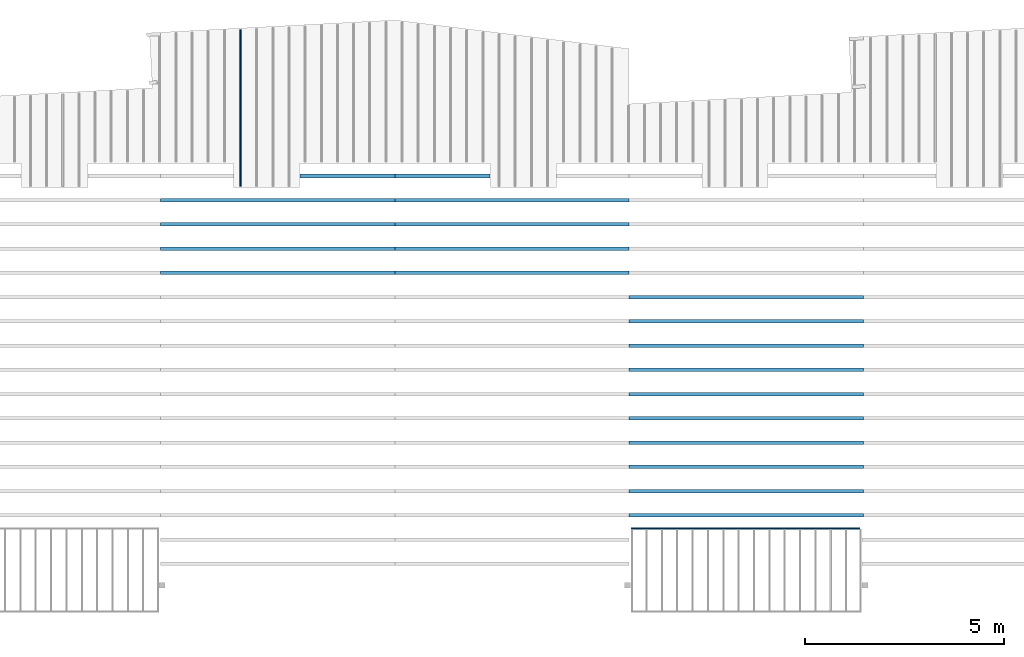
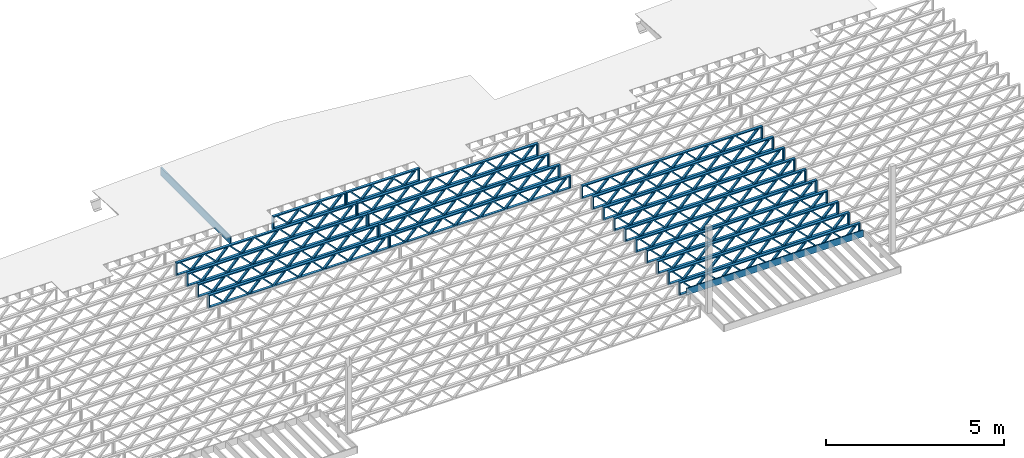
# One storey, part 7 of 12: 22 beams, 4 elements without a shape of their own.
"""IFC4 building model written with IfcOpenShell, lengths in feet."""

from ifc_helpers import new_model, entity, si_unit, converted_unit, derived_unit, direction, frame, frame_2d, origin, origin_2d_with_axis, place, context, subcontext, project, spatial, rectangle, extrude, source, transform, mapped, material, material_profile, profile_set, profile_usage, type_object, type_shapes, element, aggregate, save


model = new_model("IFC4")

# Units and contexts
model_context = context("Model", 3, precision=0.0001, world=origin(), true_north=direction((6.12303176911189e-17, 1.0)))
body_context = subcontext(model_context, "Body", "Model", "MODEL_VIEW")
ifc_project = project(units=[converted_unit("LENGTHUNIT", "FOOT", entity("IfcRatioMeasure", 0.3048), si_unit("LENGTHUNIT", "METRE"), dimensions=[1, 0, 0, 0, 0, 0, 0]), converted_unit("AREAUNIT", "SQUARE FOOT", entity("IfcRatioMeasure", 0.09290304), si_unit("AREAUNIT", "SQUARE_METRE"), dimensions=[2, 0, 0, 0, 0, 0, 0]), converted_unit("VOLUMEUNIT", "CUBIC FOOT", entity("IfcRatioMeasure", 0.028316846592), si_unit("VOLUMEUNIT", "CUBIC_METRE"), dimensions=[3, 0, 0, 0, 0, 0, 0]), converted_unit("PLANEANGLEUNIT", "DEGREE", entity("IfcRatioMeasure", 0.0174532925199433), si_unit("PLANEANGLEUNIT", "RADIAN"), dimensions=[0, 0, 0, 0, 0, 0, 0]), si_unit("MASSUNIT", "GRAM", prefix="KILO"), derived_unit("MASSDENSITYUNIT", [(si_unit("MASSUNIT", "GRAM", prefix="KILO"), 1), (si_unit("LENGTHUNIT", "METRE"), -3)]), derived_unit("MOMENTOFINERTIAUNIT", [(si_unit("LENGTHUNIT", "METRE"), 4)]), si_unit("TIMEUNIT", "SECOND"), si_unit("FREQUENCYUNIT", "HERTZ"), si_unit("THERMODYNAMICTEMPERATUREUNIT", "DEGREE_CELSIUS"), derived_unit("THERMALTRANSMITTANCEUNIT", [(si_unit("MASSUNIT", "GRAM", prefix="KILO"), 1), (si_unit("THERMODYNAMICTEMPERATUREUNIT", "KELVIN"), -1), (si_unit("TIMEUNIT", "SECOND"), -3)]), derived_unit("VOLUMETRICFLOWRATEUNIT", [(si_unit("LENGTHUNIT", "METRE"), 3), (si_unit("TIMEUNIT", "SECOND"), -1)]), si_unit("ELECTRICCURRENTUNIT", "AMPERE"), si_unit("ELECTRICVOLTAGEUNIT", "VOLT"), si_unit("POWERUNIT", "WATT"), si_unit("FORCEUNIT", "NEWTON"), si_unit("ILLUMINANCEUNIT", "LUX"), si_unit("LUMINOUSFLUXUNIT", "LUMEN"), si_unit("LUMINOUSINTENSITYUNIT", "CANDELA"), derived_unit("USERDEFINED", [(si_unit("MASSUNIT", "GRAM", prefix="KILO"), -1), (si_unit("LENGTHUNIT", "METRE"), -2), (si_unit("TIMEUNIT", "SECOND"), 3), (si_unit("LUMINOUSFLUXUNIT", "LUMEN"), 1)]), derived_unit("LINEARVELOCITYUNIT", [(si_unit("LENGTHUNIT", "METRE"), 1), (si_unit("TIMEUNIT", "SECOND"), -1)]), si_unit("PRESSUREUNIT", "PASCAL"), derived_unit("USERDEFINED", [(si_unit("LENGTHUNIT", "METRE"), -2), (si_unit("MASSUNIT", "GRAM", prefix="KILO"), 1), (si_unit("TIMEUNIT", "SECOND"), -2)]), derived_unit("LINEARFORCEUNIT", [(si_unit("MASSUNIT", "GRAM", prefix="KILO"), 1), (si_unit("LENGTHUNIT", "METRE"), 1), (si_unit("TIMEUNIT", "SECOND"), -2), (si_unit("LENGTHUNIT", "METRE"), -1)]), derived_unit("PLANARFORCEUNIT", [(si_unit("MASSUNIT", "GRAM", prefix="KILO"), 1), (si_unit("LENGTHUNIT", "METRE"), 1), (si_unit("TIMEUNIT", "SECOND"), -2), (si_unit("LENGTHUNIT", "METRE"), -2)])], contexts=[model_context])

# Site, building, storey
site_placement = place(None, origin())
site = spatial("IfcSite", under=ifc_project, at=site_placement, CompositionType="ELEMENT")
building_placement = place(site_placement, origin())
building = spatial("IfcBuilding", under=site, at=building_placement, CompositionType="ELEMENT")
storey_placement = place(building_placement, frame((0.0, 0.0, 21.46875)))
storey = spatial("IfcBuildingStorey", under=building, at=storey_placement, Name="3RD FLOOR", CompositionType="ELEMENT", Elevation=21.46875)

# Assembly, beams
assembly_1_placement = place(storey_placement, origin())
assembly_1 = element("IfcElementAssembly", 1, at=assembly_1_placement, inside=storey, Name="Structural Beam System:Structural Framing System", ObjectType="Structural Beam System:Structural Framing System", AssemblyPlace="NOTDEFINED", PredefinedType="BEAM_GRID")
ifc_material_1 = material(Name="WOOD TRUSS", Category="Materials")
ifc_material_profile_1 = material_profile(ifc_material_1, rectangle(XDim=1.73473973950632, YDim=0.125, at=frame_2d((-1.11022302462516e-16, 8.32667268468867e-17), x_axis=(1.0, 0.0))))
ifc_material_profile_2 = material_profile(ifc_material_1, rectangle(XDim=1.73473973950633, YDim=0.125, at=frame_2d((-1.11022302462516e-16, 8.32667268468867e-17), x_axis=(1.0, 0.0))))
ifc_material_profile_3 = material_profile(ifc_material_1, rectangle(XDim=1.73473973950632, YDim=0.125, at=frame_2d((-5.55111512312578e-17, 1.38777878078145e-16), x_axis=(1.0, 0.0))))
ifc_material_profile_4 = material_profile(ifc_material_1, rectangle(XDim=1.73473973950633, YDim=0.125, at=frame_2d((-1.11022302462516e-16, 8.32667268468867e-17), x_axis=(1.0, 0.0))))
ifc_material_profile_5 = material_profile(ifc_material_1, rectangle(XDim=1.73473973950632, YDim=0.125, at=frame_2d((-1.11022302462516e-16, 8.32667268468867e-17), x_axis=(1.0, 0.0))))
ifc_material_profile_6 = material_profile(ifc_material_1, rectangle(XDim=1.73473973950633, YDim=0.125, at=frame_2d((-2.77555756156289e-16, 3.05311331771918e-16), x_axis=(1.0, 0.0))))
ifc_material_profile_7 = material_profile(ifc_material_1, rectangle(XDim=1.73473973950632, YDim=0.124999999999999, at=frame_2d((-3.88578058618805e-16, -2.4980018054066e-16), x_axis=(1.0, 0.0))))
ifc_material_profile_8 = material_profile(ifc_material_1, rectangle(XDim=1.73473973950633, YDim=0.125, at=frame_2d((2.77555756156289e-16, -3.05311331771918e-16), x_axis=(1.0, 0.0))))
ifc_material_profile_9 = material_profile(ifc_material_1, rectangle(XDim=1.73473973950632, YDim=0.124999999999999, at=frame_2d((-1.11022302462516e-16, 8.32667268468867e-17), x_axis=(1.0, 0.0))))
ifc_material_profile_10 = material_profile(ifc_material_1, rectangle(XDim=1.73473973950633, YDim=0.125, at=origin_2d_with_axis()))
ifc_material_profile_11 = material_profile(ifc_material_1, rectangle(XDim=0.124999999999982, YDim=0.291666666666668, at=origin_2d_with_axis()))
ifc_material_profile_12 = material_profile(ifc_material_1, rectangle(XDim=0.124999999999932, YDim=0.291666666666664, at=origin_2d_with_axis()))
ifc_material_profile_13 = material_profile(ifc_material_1, rectangle(XDim=1.25000000000002, YDim=0.29166666666667, at=origin_2d_with_axis()))
ifc_material_profile_14 = material_profile(ifc_material_1, rectangle(XDim=1.25000000000004, YDim=0.291666666666667, at=origin_2d_with_axis()))
ifc_profile_set_1 = profile_set([ifc_material_profile_1, ifc_material_profile_2, ifc_material_profile_3, ifc_material_profile_4, ifc_material_profile_5, ifc_material_profile_6, ifc_material_profile_7, ifc_material_profile_8, ifc_material_profile_9, ifc_material_profile_10, ifc_material_profile_11, ifc_material_profile_12, ifc_material_profile_13, ifc_material_profile_14])
ifc_profile_usage_1 = profile_usage(ifc_profile_set_1, cardinal=8)
beam_type_1 = type_object("IfcBeamType", PredefinedType="BEAM", material=ifc_profile_set_1)
shared_shape_1 = source(origin(), body_context, "Body", "SweptSolid", [
    extrude(rectangle(XDim=1.73473973950632, YDim=0.124999999999999, at=frame_2d((5.55111512312578e-16, 7.21644966006352e-16), x_axis=(1.0, 0.0))), frame((5.95847627016997, -0.145833333333334, 0.0), z_axis=(0.0, 1.0, 0.0), x_axis=(0.693383046997606, 0.0, 0.720569184836762)), (0.0, 0.0, 1.0), 0.291666666666667),
    extrude(rectangle(XDim=1.73473973950633, YDim=0.125, at=origin_2d_with_axis()), frame((4.7081903964967, -0.145833333333334, 0.0), z_axis=(0.0, 1.0, 0.0), x_axis=(0.69338304699761, 0.0, -0.720569184836758)), (0.0, 0.0, 1.0), 0.291666666666666),
    extrude(rectangle(XDim=1.73473973950632, YDim=0.125, at=frame_2d((2.22044604925031e-16, 3.88578058618805e-16), x_axis=(1.0, 0.0))), frame((3.29180960350347, -0.145833333333334, 0.0), z_axis=(0.0, 1.0, 0.0), x_axis=(0.693383046997606, 0.0, 0.720569184836762)), (0.0, 0.0, 1.0), 0.291666666666667),
    extrude(rectangle(XDim=1.73473973950633, YDim=0.125, at=frame_2d((1.11022302462516e-16, -8.32667268468867e-17), x_axis=(1.0, 0.0))), frame((2.0415237298302, -0.145833333333334, 0.0), z_axis=(0.0, 1.0, 0.0), x_axis=(0.69338304699761, 0.0, -0.720569184836758)), (0.0, 0.0, 1.0), 0.291666666666667),
    extrude(rectangle(XDim=1.73473973950632, YDim=0.125, at=frame_2d((-5.55111512312578e-17, 1.38777878078145e-16), x_axis=(1.0, 0.0))), frame((0.625142936836964, -0.145833333333334, 0.0), z_axis=(0.0, 1.0, 0.0), x_axis=(0.693383046997606, 0.0, 0.720569184836762)), (0.0, 0.0, 1.0), 0.291666666666667),
    extrude(rectangle(XDim=1.73473973950633, YDim=0.125, at=frame_2d((-1.11022302462516e-16, 8.32667268468867e-17), x_axis=(1.0, 0.0))), frame((-0.625142936836306, -0.145833333333334, 0.0), z_axis=(0.0, 1.0, 0.0), x_axis=(0.69338304699761, 0.0, -0.720569184836758)), (0.0, 0.0, 1.0), 0.291666666666667),
    extrude(rectangle(XDim=1.73473973950632, YDim=0.125, at=frame_2d((-1.11022302462516e-16, 8.32667268468867e-17), x_axis=(1.0, 0.0))), frame((-2.04152372982954, -0.145833333333334, 0.0), z_axis=(0.0, 1.0, 0.0), x_axis=(0.693383046997606, 0.0, 0.720569184836762)), (0.0, 0.0, 1.0), 0.291666666666667),
    extrude(rectangle(XDim=1.73473973950633, YDim=0.125, at=origin_2d_with_axis()), frame((-3.29180960350281, -0.145833333333334, 0.0), z_axis=(0.0, 1.0, 0.0), x_axis=(0.69338304699761, 0.0, -0.720569184836758)), (0.0, 0.0, 1.0), 0.291666666666667),
    extrude(rectangle(XDim=1.73473973950632, YDim=0.124999999999999, at=frame_2d((-1.11022302462516e-16, 8.32667268468867e-17), x_axis=(1.0, 0.0))), frame((-4.70819039649604, -0.145833333333334, 0.0), z_axis=(0.0, 1.0, 0.0), x_axis=(0.693383046997606, 0.0, 0.720569184836762)), (0.0, 0.0, 1.0), 0.291666666666667),
    extrude(rectangle(XDim=1.73473973950633, YDim=0.125, at=frame_2d((-5.55111512312578e-16, 6.38378239159465e-16), x_axis=(1.0, 0.0))), frame((-5.95847627016931, -0.145833333333334, 0.0), z_axis=(0.0, 1.0, 0.0), x_axis=(0.69338304699761, 0.0, -0.720569184836758)), (0.0, 0.0, 1.0), 0.291666666666666),
    extrude(rectangle(XDim=1.73473973950632, YDim=0.125, at=frame_2d((-7.21644966006352e-16, -5.82867087928207e-16), x_axis=(1.0, 0.0))), frame((8.62514293683647, -0.145833333333334, 0.0), z_axis=(0.0, 1.0, 0.0), x_axis=(0.693383046997607, 0.0, 0.720569184836761)), (0.0, 0.0, 1.0), 0.291666666666667),
    extrude(rectangle(XDim=1.73473973950633, YDim=0.125, at=origin_2d_with_axis()), frame((7.3748570631632, -0.145833333333334, 0.0), z_axis=(0.0, 1.0, 0.0), x_axis=(0.69338304699761, 0.0, -0.720569184836758)), (0.0, 0.0, 1.0), 0.291666666666666),
    extrude(rectangle(XDim=1.73473973950632, YDim=0.124999999999999, at=frame_2d((-1.11022302462516e-16, 8.32667268468867e-17), x_axis=(1.0, 0.0))), frame((-7.37485706316255, -0.145833333333334, 0.0), z_axis=(0.0, 1.0, 0.0), x_axis=(0.693383046997606, 0.0, 0.720569184836762)), (0.0, 0.0, 1.0), 0.291666666666667),
    extrude(rectangle(XDim=1.73473973950633, YDim=0.125, at=origin_2d_with_axis()), frame((-8.62514293683582, -0.145833333333334, 0.0), z_axis=(0.0, 1.0, 0.0), x_axis=(0.69338304699761, 0.0, -0.720569184836758)), (0.0, 0.0, 1.0), 0.291666666666666),
    extrude(rectangle(XDim=0.124999999999982, YDim=0.291666666666668, at=origin_2d_with_axis()), frame((-9.66666666666609, 0.0, 0.687500000000054), z_axis=(1.0, 0.0, 0.0), x_axis=(0.0, 0.0, -1.0)), (0.0, 0.0, 1.0), 19.3333333333322),
    extrude(rectangle(XDim=0.124999999999932, YDim=0.291666666666664, at=origin_2d_with_axis()), frame((-9.66666666666588, 0.0, -0.687499999999984), z_axis=(1.0, 0.0, 0.0), x_axis=(0.0, 0.0, -1.0)), (0.0, 0.0, 1.0), 19.333333333332),
    extrude(rectangle(XDim=1.25000000000002, YDim=0.29166666666667, at=origin_2d_with_axis()), frame((9.54166666666607, 0.0, 0.0), z_axis=(1.0, 0.0, 0.0), x_axis=(0.0, 0.0, -1.0)), (0.0, 0.0, 1.0), 0.12500000000002),
    extrude(rectangle(XDim=1.25000000000004, YDim=0.291666666666667, at=origin_2d_with_axis()), frame((-9.66666666666609, 0.0, 0.0), z_axis=(1.0, 0.0, 0.0), x_axis=(0.0, 0.0, -1.0)), (0.0, 0.0, 1.0), 0.125000000000023),
])
type_shapes(beam_type_1, [shared_shape_1])
beam_1_placement = place(assembly_1_placement, frame((-174.071493818896, 947.861934882651, -0.947916666666661), z_axis=(0.0, 0.0, 1.0), x_axis=(-1.0, 0.0, 0.0)))
beam_1 = element("IfcBeam", 2, at=beam_1_placement, type_object=beam_type_1, material=ifc_profile_usage_1, PredefinedType="BEAM", context=body_context, shape_type="MappedRepresentation", body=[
    mapped(shared_shape_1, transform((0.0, 0.0, 0.0), scale=1.0)),
])
ifc_profile_usage_2 = profile_usage(ifc_profile_set_1, cardinal=8)
beam_2_placement = place(assembly_1_placement, frame((-174.071493818896, 945.861934882651, -0.947916666666661), z_axis=(0.0, 0.0, 1.0), x_axis=(-1.0, 0.0, 0.0)))
beam_2 = element("IfcBeam", 3, at=beam_2_placement, type_object=beam_type_1, material=ifc_profile_usage_2, PredefinedType="BEAM", context=body_context, shape_type="MappedRepresentation", body=[
    mapped(shared_shape_1, transform((0.0, 0.0, 0.0), scale=1.0)),
])
ifc_profile_usage_3 = profile_usage(ifc_profile_set_1, cardinal=8)
beam_3_placement = place(assembly_1_placement, frame((-174.071493818896, 943.861934882651, -0.947916666666661), z_axis=(0.0, 0.0, 1.0), x_axis=(-1.0, 0.0, 0.0)))
beam_3 = element("IfcBeam", 4, at=beam_3_placement, type_object=beam_type_1, material=ifc_profile_usage_3, PredefinedType="BEAM", context=body_context, shape_type="MappedRepresentation", body=[
    mapped(shared_shape_1, transform((0.0, 0.0, 0.0), scale=1.0)),
])
ifc_profile_usage_4 = profile_usage(ifc_profile_set_1, cardinal=8)
beam_4_placement = place(assembly_1_placement, frame((-174.071493818896, 941.861934882651, -0.947916666666661), z_axis=(0.0, 0.0, 1.0), x_axis=(-1.0, 0.0, 0.0)))
beam_4 = element("IfcBeam", 5, at=beam_4_placement, type_object=beam_type_1, material=ifc_profile_usage_4, PredefinedType="BEAM", context=body_context, shape_type="MappedRepresentation", body=[
    mapped(shared_shape_1, transform((0.0, 0.0, 0.0), scale=1.0)),
])
ifc_profile_usage_5 = profile_usage(ifc_profile_set_1, cardinal=8)
beam_5_placement = place(assembly_1_placement, frame((-174.071493818896, 939.861934882651, -0.947916666666661), z_axis=(0.0, 0.0, 1.0), x_axis=(-1.0, 0.0, 0.0)))
beam_5 = element("IfcBeam", 6, at=beam_5_placement, type_object=beam_type_1, material=ifc_profile_usage_5, PredefinedType="BEAM", context=body_context, shape_type="MappedRepresentation", body=[
    mapped(shared_shape_1, transform((0.0, 0.0, 0.0), scale=1.0)),
])
ifc_profile_usage_6 = profile_usage(ifc_profile_set_1, cardinal=8)
beam_6_placement = place(assembly_1_placement, frame((-174.071493818896, 937.861934882651, -0.947916666666661), z_axis=(0.0, 0.0, 1.0), x_axis=(-1.0, 0.0, 0.0)))
beam_6 = element("IfcBeam", 7, at=beam_6_placement, type_object=beam_type_1, material=ifc_profile_usage_6, PredefinedType="BEAM", context=body_context, shape_type="MappedRepresentation", body=[
    mapped(shared_shape_1, transform((0.0, 0.0, 0.0), scale=1.0)),
])
ifc_profile_usage_7 = profile_usage(ifc_profile_set_1, cardinal=8)
beam_7_placement = place(assembly_1_placement, frame((-174.071493818896, 935.861934882651, -0.947916666666661), z_axis=(0.0, 0.0, 1.0), x_axis=(-1.0, 0.0, 0.0)))
beam_7 = element("IfcBeam", 8, at=beam_7_placement, type_object=beam_type_1, material=ifc_profile_usage_7, PredefinedType="BEAM", context=body_context, shape_type="MappedRepresentation", body=[
    mapped(shared_shape_1, transform((0.0, 0.0, 0.0), scale=1.0)),
])
ifc_profile_usage_8 = profile_usage(ifc_profile_set_1, cardinal=8)
beam_8_placement = place(assembly_1_placement, frame((-174.071493818896, 933.861934882651, -0.947916666666661), z_axis=(0.0, 0.0, 1.0), x_axis=(-1.0, 0.0, 0.0)))
beam_8 = element("IfcBeam", 9, at=beam_8_placement, type_object=beam_type_1, material=ifc_profile_usage_8, PredefinedType="BEAM", context=body_context, shape_type="MappedRepresentation", body=[
    mapped(shared_shape_1, transform((0.0, 0.0, 0.0), scale=1.0)),
])
ifc_profile_usage_9 = profile_usage(ifc_profile_set_1, cardinal=8)
beam_9_placement = place(assembly_1_placement, frame((-174.071493818896, 931.861934882651, -0.947916666666661), z_axis=(0.0, 0.0, 1.0), x_axis=(-1.0, 0.0, 0.0)))
beam_9 = element("IfcBeam", 10, at=beam_9_placement, type_object=beam_type_1, material=ifc_profile_usage_9, PredefinedType="BEAM", context=body_context, shape_type="MappedRepresentation", body=[
    mapped(shared_shape_1, transform((0.0, 0.0, 0.0), scale=1.0)),
])
ifc_profile_usage_10 = profile_usage(ifc_profile_set_1, cardinal=8)
beam_10_placement = place(assembly_1_placement, frame((-174.071493818896, 929.861934882651, -0.947916666666661), z_axis=(0.0, 0.0, 1.0), x_axis=(-1.0, 0.0, 0.0)))
beam_10 = element("IfcBeam", 11, at=beam_10_placement, type_object=beam_type_1, material=ifc_profile_usage_10, PredefinedType="BEAM", context=body_context, shape_type="MappedRepresentation", body=[
    mapped(shared_shape_1, transform((0.0, 0.0, 0.0), scale=1.0)),
])
aggregate(assembly_1, [beam_1, beam_2, beam_3, beam_4, beam_5, beam_6, beam_7, beam_8, beam_9, beam_10])

assembly_2_placement = place(storey_placement, origin())
assembly_2 = element("IfcElementAssembly", 12, at=assembly_2_placement, inside=storey, Name="Structural Beam System:Structural Framing System", ObjectType="Structural Beam System:Structural Framing System", AssemblyPlace="NOTDEFINED", PredefinedType="BEAM_GRID")
ifc_profile_usage_11 = profile_usage(ifc_profile_set_1, cardinal=8)
beam_11_placement = place(assembly_2_placement, frame((-193.404827152229, 953.861934882651, -0.947916666666881)))
beam_11 = element("IfcBeam", 13, at=beam_11_placement, type_object=beam_type_1, material=ifc_profile_usage_11, PredefinedType="BEAM", context=body_context, shape_type="MappedRepresentation", body=[
    mapped(shared_shape_1, transform((0.0, 0.0, 0.0), scale=1.0)),
])
ifc_profile_usage_12 = profile_usage(ifc_profile_set_1, cardinal=8)
beam_12_placement = place(assembly_2_placement, frame((-193.404827152229, 951.861934882651, -0.947916666666881)))
beam_12 = element("IfcBeam", 14, at=beam_12_placement, type_object=beam_type_1, material=ifc_profile_usage_12, PredefinedType="BEAM", context=body_context, shape_type="MappedRepresentation", body=[
    mapped(shared_shape_1, transform((0.0, 0.0, 0.0), scale=1.0)),
])
ifc_profile_usage_13 = profile_usage(ifc_profile_set_1, cardinal=8)
beam_13_placement = place(assembly_2_placement, frame((-193.404827152229, 949.861934882651, -0.947916666666881)))
beam_13 = element("IfcBeam", 15, at=beam_13_placement, type_object=beam_type_1, material=ifc_profile_usage_13, PredefinedType="BEAM", context=body_context, shape_type="MappedRepresentation", body=[
    mapped(shared_shape_1, transform((0.0, 0.0, 0.0), scale=1.0)),
])

assembly_3_placement = place(storey_placement, origin())
assembly_3 = element("IfcElementAssembly", 16, at=assembly_3_placement, inside=storey, Name="Structural Beam System:Structural Framing System", ObjectType="Structural Beam System:Structural Framing System", AssemblyPlace="NOTDEFINED", PredefinedType="BEAM_GRID")
ifc_profile_usage_14 = profile_usage(ifc_profile_set_1, cardinal=8)
beam_14_placement = place(assembly_3_placement, frame((-212.738160485495, 955.861934882651, -0.947916666666881), z_axis=(0.0, 0.0, 1.0), x_axis=(-1.0, 0.0, 0.0)))
beam_14 = element("IfcBeam", 17, at=beam_14_placement, type_object=beam_type_1, material=ifc_profile_usage_14, PredefinedType="BEAM", context=body_context, shape_type="MappedRepresentation", body=[
    mapped(shared_shape_1, transform((0.0, 0.0, 0.0), scale=1.0)),
])
ifc_profile_usage_15 = profile_usage(ifc_profile_set_1, cardinal=8)
beam_15_placement = place(assembly_3_placement, frame((-212.738160485495, 953.861934882651, -0.947916666666881), z_axis=(0.0, 0.0, 1.0), x_axis=(-1.0, 0.0, 0.0)))
beam_15 = element("IfcBeam", 18, at=beam_15_placement, type_object=beam_type_1, material=ifc_profile_usage_15, PredefinedType="BEAM", context=body_context, shape_type="MappedRepresentation", body=[
    mapped(shared_shape_1, transform((0.0, 0.0, 0.0), scale=1.0)),
])
ifc_profile_usage_16 = profile_usage(ifc_profile_set_1, cardinal=8)
beam_16_placement = place(assembly_3_placement, frame((-212.738160485495, 951.861934882651, -0.947916666666881), z_axis=(0.0, 0.0, 1.0), x_axis=(-1.0, 0.0, 0.0)))
beam_16 = element("IfcBeam", 19, at=beam_16_placement, type_object=beam_type_1, material=ifc_profile_usage_16, PredefinedType="BEAM", context=body_context, shape_type="MappedRepresentation", body=[
    mapped(shared_shape_1, transform((0.0, 0.0, 0.0), scale=1.0)),
])
ifc_profile_usage_17 = profile_usage(ifc_profile_set_1, cardinal=8)
beam_17_placement = place(assembly_3_placement, frame((-212.738160485495, 949.861934882651, -0.947916666666881), z_axis=(0.0, 0.0, 1.0), x_axis=(-1.0, 0.0, 0.0)))
beam_17 = element("IfcBeam", 20, at=beam_17_placement, type_object=beam_type_1, material=ifc_profile_usage_17, PredefinedType="BEAM", context=body_context, shape_type="MappedRepresentation", body=[
    mapped(shared_shape_1, transform((0.0, 0.0, 0.0), scale=1.0)),
])

# Beam
ifc_profile_usage_18 = profile_usage(ifc_profile_set_1, cardinal=8)
beam_type_2 = type_object("IfcBeamType", PredefinedType="BEAM", material=ifc_profile_set_1)
shared_shape_2 = source(origin(), body_context, "Body", "SweptSolid", [
    extrude(rectangle(XDim=1.73473973950632, YDim=0.125, at=frame_2d((-5.55111512312578e-17, 1.38777878078145e-16), x_axis=(1.0, 0.0))), frame((0.625142936836963, -0.145833333333334, 0.0), z_axis=(0.0, 1.0, 0.0), x_axis=(0.693383046997606, 0.0, 0.720569184836762)), (0.0, 0.0, 1.0), 0.291666666666667),
    extrude(rectangle(XDim=1.73473973950633, YDim=0.125, at=frame_2d((-1.11022302462516e-16, 8.32667268468867e-17), x_axis=(1.0, 0.0))), frame((-0.625142936836308, -0.145833333333334, 0.0), z_axis=(0.0, 1.0, 0.0), x_axis=(0.69338304699761, 0.0, -0.720569184836758)), (0.0, 0.0, 1.0), 0.291666666666667),
    extrude(rectangle(XDim=1.73473973950632, YDim=0.125, at=frame_2d((-1.11022302462516e-16, 8.32667268468867e-17), x_axis=(1.0, 0.0))), frame((2.87514285312432, -0.145833333333334, 0.0), z_axis=(0.0, 1.0, 0.0), x_axis=(0.693383046997606, 0.0, 0.720569184836762)), (0.0, 0.0, 1.0), 0.291666666666667),
    extrude(rectangle(XDim=1.73473973950633, YDim=0.125, at=frame_2d((-1.11022302462516e-16, 8.32667268468867e-17), x_axis=(1.0, 0.0))), frame((1.62485697945105, -0.145833333333334, 0.0), z_axis=(0.0, 1.0, 0.0), x_axis=(0.69338304699761, 0.0, -0.720569184836758)), (0.0, 0.0, 1.0), 0.291666666666667),
    extrude(rectangle(XDim=1.73473973950632, YDim=0.125, at=frame_2d((-1.11022302462516e-16, 8.32667268468867e-17), x_axis=(1.0, 0.0))), frame((-1.62485697945039, -0.145833333333334, 0.0), z_axis=(0.0, 1.0, 0.0), x_axis=(0.693383046997606, 0.0, 0.720569184836762)), (0.0, 0.0, 1.0), 0.291666666666667),
    extrude(rectangle(XDim=1.73473973950633, YDim=0.125, at=origin_2d_with_axis()), frame((-2.87514285312366, -0.145833333333334, 0.0), z_axis=(0.0, 1.0, 0.0), x_axis=(0.69338304699761, 0.0, -0.720569184836758)), (0.0, 0.0, 1.0), 0.291666666666667),
    extrude(rectangle(XDim=0.124999999999982, YDim=0.291666666666668, at=origin_2d_with_axis()), frame((-3.91666658295394, 0.0, 0.687500000000054), z_axis=(1.0, 0.0, 0.0), x_axis=(0.0, 0.0, -1.0)), (0.0, 0.0, 1.0), 7.83333316590787),
    extrude(rectangle(XDim=0.124999999999932, YDim=0.291666666666664, at=origin_2d_with_axis()), frame((-3.91666658295372, 0.0, -0.687499999999984), z_axis=(1.0, 0.0, 0.0), x_axis=(0.0, 0.0, -1.0)), (0.0, 0.0, 1.0), 7.83333316590766),
    extrude(rectangle(XDim=1.25000000000002, YDim=0.29166666666667, at=origin_2d_with_axis()), frame((3.79166658295392, 0.0, 0.0), z_axis=(1.0, 0.0, 0.0), x_axis=(0.0, 0.0, -1.0)), (0.0, 0.0, 1.0), 0.12500000000002),
    extrude(rectangle(XDim=1.25000000000004, YDim=0.291666666666667, at=origin_2d_with_axis()), frame((-3.91666658295394, 0.0, 0.0), z_axis=(1.0, 0.0, 0.0), x_axis=(0.0, 0.0, -1.0)), (0.0, 0.0, 1.0), 0.125000000000023),
])
type_shapes(beam_type_2, [shared_shape_2])
beam_18_placement = place(assembly_2_placement, frame((-199.154827235941, 957.861934882651, -0.947916666666881)))
beam_18 = element("IfcBeam", 21, at=beam_18_placement, type_object=beam_type_2, material=ifc_profile_usage_18, PredefinedType="BEAM", context=body_context, shape_type="MappedRepresentation", body=[
    mapped(shared_shape_2, transform((0.0, 0.0, 0.0), scale=1.0)),
])

ifc_profile_usage_19 = profile_usage(ifc_profile_set_1, cardinal=8)
beam_19_placement = place(assembly_3_placement, frame((-206.988160401783, 957.861934882651, -0.947916666666881), z_axis=(0.0, 0.0, 1.0), x_axis=(-1.0, 0.0, 0.0)))
beam_19 = element("IfcBeam", 22, at=beam_19_placement, type_object=beam_type_2, material=ifc_profile_usage_19, PredefinedType="BEAM", context=body_context, shape_type="MappedRepresentation", body=[
    mapped(shared_shape_2, transform((0.0, 0.0, 0.0), scale=1.0)),
])

aggregate(assembly_3, [beam_19, beam_14, beam_15, beam_16, beam_17])

ifc_profile_usage_20 = profile_usage(ifc_profile_set_1, cardinal=8)
beam_type_3 = type_object("IfcBeamType", PredefinedType="BEAM", material=ifc_profile_set_1)
shared_shape_3 = source(origin(), body_context, "Body", "SweptSolid", [
    extrude(rectangle(XDim=1.73473973950632, YDim=0.124999999999999, at=frame_2d((5.55111512312578e-16, 7.21644966006352e-16), x_axis=(1.0, 0.0))), frame((5.95847627016989, -0.145833333333334, 0.0), z_axis=(0.0, 1.0, 0.0), x_axis=(0.693383046997606, 0.0, 0.720569184836762)), (0.0, 0.0, 1.0), 0.291666666666667),
    extrude(rectangle(XDim=1.73473973950633, YDim=0.125, at=origin_2d_with_axis()), frame((4.70819039649662, -0.145833333333334, 0.0), z_axis=(0.0, 1.0, 0.0), x_axis=(0.69338304699761, 0.0, -0.720569184836758)), (0.0, 0.0, 1.0), 0.291666666666666),
    extrude(rectangle(XDim=1.73473973950632, YDim=0.125, at=frame_2d((2.22044604925031e-16, 3.88578058618805e-16), x_axis=(1.0, 0.0))), frame((3.29180960350342, -0.145833333333334, 0.0), z_axis=(0.0, 1.0, 0.0), x_axis=(0.693383046997606, 0.0, 0.720569184836762)), (0.0, 0.0, 1.0), 0.291666666666667),
    extrude(rectangle(XDim=1.73473973950633, YDim=0.125, at=frame_2d((1.11022302462516e-16, -8.32667268468867e-17), x_axis=(1.0, 0.0))), frame((2.04152372983015, -0.145833333333334, 0.0), z_axis=(0.0, 1.0, 0.0), x_axis=(0.69338304699761, 0.0, -0.720569184836758)), (0.0, 0.0, 1.0), 0.291666666666667),
    extrude(rectangle(XDim=1.73473973950632, YDim=0.125, at=frame_2d((-5.55111512312578e-17, 1.38777878078145e-16), x_axis=(1.0, 0.0))), frame((0.625142936836964, -0.145833333333334, 0.0), z_axis=(0.0, 1.0, 0.0), x_axis=(0.693383046997606, 0.0, 0.720569184836762)), (0.0, 0.0, 1.0), 0.291666666666667),
    extrude(rectangle(XDim=1.73473973950633, YDim=0.125, at=frame_2d((-1.11022302462516e-16, 8.32667268468867e-17), x_axis=(1.0, 0.0))), frame((-0.625142936836306, -0.145833333333334, 0.0), z_axis=(0.0, 1.0, 0.0), x_axis=(0.69338304699761, 0.0, -0.720569184836758)), (0.0, 0.0, 1.0), 0.291666666666667),
    extrude(rectangle(XDim=1.73473973950632, YDim=0.125, at=frame_2d((-1.11022302462516e-16, 8.32667268468867e-17), x_axis=(1.0, 0.0))), frame((-2.0415237298295, -0.145833333333334, 0.0), z_axis=(0.0, 1.0, 0.0), x_axis=(0.693383046997606, 0.0, 0.720569184836762)), (0.0, 0.0, 1.0), 0.291666666666667),
    extrude(rectangle(XDim=1.73473973950633, YDim=0.125, at=origin_2d_with_axis()), frame((-3.29180960350277, -0.145833333333334, 0.0), z_axis=(0.0, 1.0, 0.0), x_axis=(0.69338304699761, 0.0, -0.720569184836758)), (0.0, 0.0, 1.0), 0.291666666666667),
    extrude(rectangle(XDim=1.73473973950632, YDim=0.124999999999999, at=frame_2d((-1.11022302462516e-16, 8.32667268468867e-17), x_axis=(1.0, 0.0))), frame((-4.70819039649596, -0.145833333333334, 0.0), z_axis=(0.0, 1.0, 0.0), x_axis=(0.693383046997606, 0.0, 0.720569184836762)), (0.0, 0.0, 1.0), 0.291666666666667),
    extrude(rectangle(XDim=1.73473973950633, YDim=0.125, at=frame_2d((-5.55111512312578e-16, 6.38378239159465e-16), x_axis=(1.0, 0.0))), frame((-5.95847627016923, -0.145833333333334, 0.0), z_axis=(0.0, 1.0, 0.0), x_axis=(0.69338304699761, 0.0, -0.720569184836758)), (0.0, 0.0, 1.0), 0.291666666666666),
    extrude(rectangle(XDim=1.73473973950632, YDim=0.125, at=frame_2d((-7.21644966006352e-16, -5.82867087928207e-16), x_axis=(1.0, 0.0))), frame((8.62514293683635, -0.145833333333334, 0.0), z_axis=(0.0, 1.0, 0.0), x_axis=(0.693383046997607, 0.0, 0.720569184836761)), (0.0, 0.0, 1.0), 0.291666666666667),
    extrude(rectangle(XDim=1.73473973950633, YDim=0.125, at=origin_2d_with_axis()), frame((7.37485706316307, -0.145833333333334, 0.0), z_axis=(0.0, 1.0, 0.0), x_axis=(0.69338304699761, 0.0, -0.720569184836758)), (0.0, 0.0, 1.0), 0.291666666666666),
    extrude(rectangle(XDim=1.73473973950632, YDim=0.124999999999999, at=frame_2d((-1.11022302462516e-16, 8.32667268468867e-17), x_axis=(1.0, 0.0))), frame((-7.37485706316242, -0.145833333333334, 0.0), z_axis=(0.0, 1.0, 0.0), x_axis=(0.693383046997606, 0.0, 0.720569184836762)), (0.0, 0.0, 1.0), 0.291666666666667),
    extrude(rectangle(XDim=1.73473973950633, YDim=0.125, at=origin_2d_with_axis()), frame((-8.62514293683569, -0.145833333333334, 0.0), z_axis=(0.0, 1.0, 0.0), x_axis=(0.69338304699761, 0.0, -0.720569184836758)), (0.0, 0.0, 1.0), 0.291666666666666),
    extrude(rectangle(XDim=0.124999999999982, YDim=0.291666666666668, at=origin_2d_with_axis()), frame((-9.66666666666596, 0.0, 0.687500000000054), z_axis=(1.0, 0.0, 0.0), x_axis=(0.0, 0.0, -1.0)), (0.0, 0.0, 1.0), 19.3333333333319),
    extrude(rectangle(XDim=0.124999999999932, YDim=0.291666666666664, at=origin_2d_with_axis()), frame((-9.66666666666575, 0.0, -0.687499999999984), z_axis=(1.0, 0.0, 0.0), x_axis=(0.0, 0.0, -1.0)), (0.0, 0.0, 1.0), 19.3333333333317),
    extrude(rectangle(XDim=1.25000000000002, YDim=0.29166666666667, at=origin_2d_with_axis()), frame((9.54166666666594, 0.0, 0.0), z_axis=(1.0, 0.0, 0.0), x_axis=(0.0, 0.0, -1.0)), (0.0, 0.0, 1.0), 0.12500000000002),
    extrude(rectangle(XDim=1.25000000000004, YDim=0.291666666666667, at=origin_2d_with_axis()), frame((-9.66666666666596, 0.0, 0.0), z_axis=(1.0, 0.0, 0.0), x_axis=(0.0, 0.0, -1.0)), (0.0, 0.0, 1.0), 0.125000000000023),
])
type_shapes(beam_type_3, [shared_shape_3])
beam_20_placement = place(assembly_2_placement, frame((-193.404827152229, 955.861934882651, -0.947916666666881)))
beam_20 = element("IfcBeam", 23, at=beam_20_placement, type_object=beam_type_3, material=ifc_profile_usage_20, PredefinedType="BEAM", context=body_context, shape_type="MappedRepresentation", body=[
    mapped(shared_shape_3, transform((0.0, 0.0, 0.0), scale=1.0)),
])

aggregate(assembly_2, [beam_18, beam_20, beam_11, beam_12, beam_13])

ifc_material_2 = material(Category="Materials")
ifc_material_profile_15 = material_profile(ifc_material_2, rectangle(XDim=0.770833333333333, YDim=0.124999999999994, at=frame_2d((-5.55111512312578e-17, 0.0), x_axis=(1.0, 0.0))))
ifc_profile_set_2 = profile_set([ifc_material_profile_15])
ifc_profile_usage_21 = profile_usage(ifc_profile_set_2, cardinal=8)
beam_type_4 = type_object("IfcBeamType", PredefinedType="BEAM", material=ifc_profile_set_2)
shared_shape_4 = source(origin(), body_context, "Body", "SweptSolid", [
    extrude(rectangle(XDim=0.770833333333333, YDim=0.124999999999994, at=frame_2d((-1.11022302462516e-16, 0.0), x_axis=(1.0, 0.0))), frame((-9.49999887751909, 0.0, 0.0), z_axis=(1.0, 0.0, 0.0), x_axis=(0.0, 0.0, -1.0)), (0.0, 0.0, 1.0), 18.8749977550382),
])
type_shapes(beam_type_4, [shared_shape_4])
beam_21_placement = place(storey_placement, frame((-174.071491964864, 928.757768215985, -0.645833333333506)))
element("IfcBeam", 24, at=beam_21_placement, inside=storey, type_object=beam_type_4, material=ifc_profile_usage_21, PredefinedType="BEAM", context=body_context, shape_type="MappedRepresentation", body=[
    mapped(shared_shape_4, transform((0.0, 0.0, 0.0), scale=1.0)),
])

# Assembly, beam
assembly_4_placement = place(storey_placement, origin())
assembly_4 = element("IfcElementAssembly", 25, at=assembly_4_placement, inside=storey, Name="Structural Beam System:Structural Framing System", ObjectType="Structural Beam System:Structural Framing System", AssemblyPlace="NOTDEFINED", PredefinedType="BEAM_GRID")
ifc_material_profile_16 = material_profile(ifc_material_2, rectangle(XDim=0.9375, YDim=0.125000000000011, at=origin_2d_with_axis()))
ifc_profile_set_3 = profile_set([ifc_material_profile_16])
ifc_profile_usage_22 = profile_usage(ifc_profile_set_3, cardinal=8)
beam_type_5 = type_object("IfcBeamType", PredefinedType="BEAM", material=ifc_profile_set_3)
shared_shape_5 = source(origin(), body_context, "Body", "SweptSolid", [
    extrude(rectangle(XDim=0.9375, YDim=0.125000000000011, at=origin_2d_with_axis()), frame((-6.45671751858674, 0.0, 0.0), z_axis=(1.0, 0.0, 0.0), x_axis=(0.0, 0.0, -1.0)), (0.0, 0.0, 1.0), 12.9134350371735),
])
type_shapes(beam_type_5, [shared_shape_5])
beam_22_placement = place(assembly_4_placement, frame((-215.810956052701, 963.486233738965, -0.729166666666714), z_axis=(0.0, 0.0, 1.0), x_axis=(0.0, 1.0, 0.0)))
beam_22 = element("IfcBeam", 26, at=beam_22_placement, type_object=beam_type_5, material=ifc_profile_usage_22, PredefinedType="BEAM", context=body_context, shape_type="MappedRepresentation", body=[
    mapped(shared_shape_5, transform((0.0, 0.0, 0.0), scale=1.0)),
])
aggregate(assembly_4, [beam_22])

save(model, "model.ifc")
